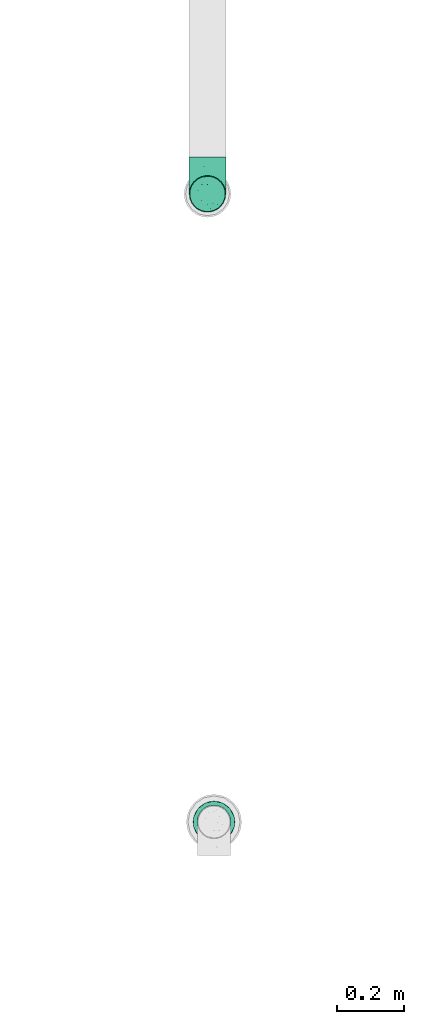
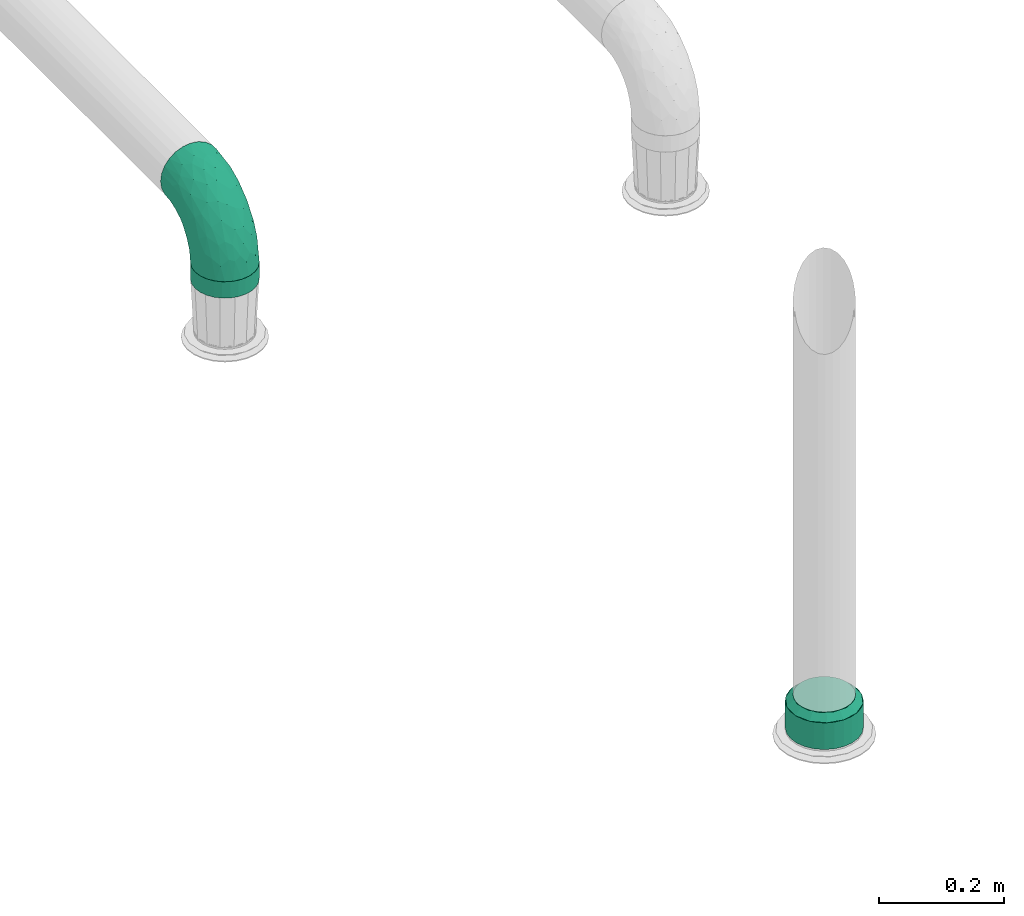
# One storey, part 29 of 103: 2 flow fittings, 1 flow segment.
"""IFC2X3 building model written with IfcOpenShell, lengths in millimetres."""

import ifcopenshell
import ifcopenshell.guid

model = None  # the IFC model being written
_history = None  # IfcOwnerHistory: only IFC2X3 demands one
_inside = {}  # id of a spatial element -> (the spatial element, [elements in it])
_under = {}  # id of a project, library or spatial element -> (it, [spatial elements below it])
_declared = {}  # id of a project -> (the project, [libraries it declares])
_typed = {}  # id of a type object -> (the type object, [elements of that type])
_made_of = {}  # id of a material, layer set ... -> (it, [elements and type objects made of it])


def new_model(schema):
    """Start an empty IFC model of exactly this schema.

    Asked for "IFC4X3", IfcOpenShell would pick the latest addendum, in which some entities
    have other attributes; the version numbers below select the first issue.
    IFC2X3 requires an IfcOwnerHistory on every rooted entity: one is made here for all.
    """
    global model, _history
    if schema == "IFC4X3":
        model = ifcopenshell.file(schema_version=(4, 3, 0, 0))
    else:
        model = ifcopenshell.file(schema=schema)
    _inside.clear()
    _under.clear()
    _declared.clear()
    _typed.clear()
    _made_of.clear()
    _history = None
    if model.schema == "IFC2X3":
        org = make("IfcOrganization", Name="unknown")
        user = make(
            "IfcPersonAndOrganization",
            ThePerson=make("IfcPerson", FamilyName="unknown"),
            TheOrganization=org,
        )
        app = make(
            "IfcApplication",
            ApplicationDeveloper=org,
            Version="unknown",
            ApplicationFullName="unknown",
            ApplicationIdentifier="unknown",
        )
        _history = make(
            "IfcOwnerHistory",
            OwningUser=user,
            OwningApplication=app,
            ChangeAction="ADDED",
            CreationDate=0,
        )
    return model


def make(cls, **values):
    """One entity of the class cls with the attributes given. An attribute that is None is left unset."""
    return model.create_entity(
        cls, **{name: value for name, value in values.items() if value is not None}
    )


def entity(cls, *values):
    """Any entity or typed value of the class cls, its attributes in the order of the schema. None: left unset."""
    e = model.create_entity(cls)
    for i, value in enumerate(values):
        if value is not None:
            e[i] = value
    return e


def rooted(cls, **values):
    """An entity with a GlobalId (a new one), such as an element, a storey or a relation."""
    return make(cls, GlobalId=ifcopenshell.guid.new(), OwnerHistory=_history, **values)


def si_unit(unit_type, name, prefix=None):
    """IfcSIUnit, for example si_unit("LENGTHUNIT", "METRE", prefix="MILLI")."""
    return make("IfcSIUnit", UnitType=unit_type, Prefix=prefix, Name=name)


def converted_unit(unit_type, name, factor, base, dimensions=None, offset=None):
    """IfcConversionBasedUnit, such as the inch: factor (a typed value) times the base unit."""
    return make(
        "IfcConversionBasedUnit"
        if offset is None
        else "IfcConversionBasedUnitWithOffset",
        ConversionOffset=offset,
        Dimensions=None
        if dimensions is None
        else entity("IfcDimensionalExponents", *dimensions),
        UnitType=unit_type,
        Name=name,
        ConversionFactor=make(
            "IfcMeasureWithUnit", ValueComponent=factor, UnitComponent=base
        ),
    )


def derived_unit(unit_type, elements):
    """IfcDerivedUnit: a product of units, each with its exponent."""
    return make(
        "IfcDerivedUnit",
        Elements=[
            make("IfcDerivedUnitElement", Unit=unit, Exponent=power)
            for unit, power in elements
        ],
        UnitType=unit_type,
    )


def assignment(units):
    """IfcUnitAssignment: the units of a project."""
    return None if units is None else make("IfcUnitAssignment", Units=units)


def point(xyz):
    """IfcCartesianPoint."""
    return None if xyz is None else make("IfcCartesianPoint", Coordinates=xyz)


def direction(xyz):
    """IfcDirection."""
    return None if xyz is None else make("IfcDirection", DirectionRatios=xyz)


def frame(location, z_axis=None, x_axis=None):
    """IfcAxis2Placement3D, a coordinate frame: its origin and axes. An axis left out is left unset."""
    return make(
        "IfcAxis2Placement3D",
        Location=point(location),
        Axis=direction(z_axis),
        RefDirection=direction(x_axis),
    )


def frame_2d(location, x_axis=None):
    """IfcAxis2Placement2D, a coordinate frame in the plane: its origin and x axis."""
    return make(
        "IfcAxis2Placement2D", Location=point(location), RefDirection=direction(x_axis)
    )


def origin_with_axes():
    """The frame at (0, 0, 0) with the z axis (0, 0, 1) and the x axis (1, 0, 0) written out."""
    return frame((0.0, 0.0, 0.0), z_axis=(0.0, 0.0, 1.0), x_axis=(1.0, 0.0, 0.0))


def origin_2d_with_axis():
    """The frame at (0, 0) in the plane with the x axis (1, 0) written out."""
    return frame_2d((0.0, 0.0), x_axis=(1.0, 0.0))


def place(relative_to, where):
    """IfcLocalPlacement: puts the frame where relative to a parent placement (None: the world)."""
    return make(
        "IfcLocalPlacement", PlacementRelTo=relative_to, RelativePlacement=where
    )


def context(
    kind, dimensions, precision=None, world=None, true_north=None, identifier=None
):
    """IfcGeometricRepresentationContext, for example the 3D "Model" context."""
    return make(
        "IfcGeometricRepresentationContext",
        ContextIdentifier=identifier,
        ContextType=kind,
        CoordinateSpaceDimension=dimensions,
        Precision=precision,
        WorldCoordinateSystem=world,
        TrueNorth=true_north,
    )


def subcontext(parent, identifier, kind, view, scale=None):
    """IfcGeometricRepresentationSubContext, for example "Body" below "Model"."""
    return make(
        "IfcGeometricRepresentationSubContext",
        ContextIdentifier=identifier,
        ContextType=kind,
        ParentContext=parent,
        TargetScale=scale,
        TargetView=view,
    )


def project(units=None, contexts=None):
    """IfcProject with its units and contexts."""
    return rooted(
        "IfcProject",
        Name="project",
        RepresentationContexts=contexts,
        UnitsInContext=assignment(units),
    )


def spatial(cls, under=None, at=None, **own):
    """A site, building, storey or space (cls), placed at a placement, below another one or the project."""
    s = rooted(cls, ObjectPlacement=at, **own)
    if under is not None:
        _under.setdefault(under.id(), (under, []))[1].append(s)
    return s


def profile(cls, at=None, kind="AREA", **sizes):
    """A parametric profile (cls). Its sizes go by their IFC names, for example OverallWidth=200.0."""
    return make(cls, ProfileType=kind, Position=at, **sizes)


def hollow_circle(**sizes):
    """IfcCircleHollowProfileDef."""
    return profile("IfcCircleHollowProfileDef", **sizes)


def extrude(swept, where, along, depth):
    """IfcExtrudedAreaSolid: the profile swept, set in the frame where, extruded along a direction by depth."""
    return make(
        "IfcExtrudedAreaSolid",
        SweptArea=swept,
        Position=where,
        ExtrudedDirection=direction(along),
        Depth=depth,
    )


def faces_of(points, faces, orient=None, outer=None):
    """IfcFace entities. A face is a list of loops; a loop is a list of indices into points, from 0.

    orient and outer hold one flag for each loop. By default every Orientation is true, the
    first loop of a face is its IfcFaceOuterBound and the others are IfcFaceBound.
    """
    made = []
    for i, loops in enumerate(faces):
        bounds = []
        for j, loop in enumerate(loops):
            is_outer = j == 0 if outer is None else outer[i][j]
            bounds.append(
                make(
                    "IfcFaceOuterBound" if is_outer else "IfcFaceBound",
                    Bound=make("IfcPolyLoop", Polygon=[points[k] for k in loop]),
                    Orientation=True if orient is None else orient[i][j],
                )
            )
        made.append(make("IfcFace", Bounds=bounds))
    return made


def open_shell(faces, orient=None, outer=None):
    """The faces of one IfcOpenShell. surface_model builds it on its shared points."""
    return ("IfcOpenShell", faces, orient, outer)


def surface_model(cls, points, shells):
    """IfcFaceBasedSurfaceModel or IfcShellBasedSurfaceModel (cls): surfaces that need not close."""
    shared = [point(p) for p in points]
    made = [make(c, CfsFaces=faces_of(shared, fs, o, b)) for c, fs, o, b in shells]
    if cls == "IfcFaceBasedSurfaceModel":
        return make(cls, FbsmFaces=made)
    return make(cls, SbsmBoundary=made)


def shape(context_of_items, identifier, shape_type, items):
    """IfcShapeRepresentation: the items that make up one representation, for example the "Body"."""
    return make(
        "IfcShapeRepresentation",
        ContextOfItems=context_of_items,
        RepresentationIdentifier=identifier,
        RepresentationType=shape_type,
        Items=items,
    )


def source(mapping_origin, context_of_items, identifier, shape_type, items):
    """IfcRepresentationMap: a shape defined once, which mapped items show again and again."""
    return make(
        "IfcRepresentationMap",
        MappingOrigin=mapping_origin,
        MappedRepresentation=shape(context_of_items, identifier, shape_type, items),
    )


def transform(
    local_origin,
    x_axis=None,
    y_axis=None,
    z_axis=None,
    scale=None,
    scale2=None,
    scale3=None,
    uniform=True,
):
    """IfcCartesianTransformationOperator3D, or its non-uniform kind. x_axis, y_axis, z_axis: its Axis1, 2, 3."""
    if uniform:
        return make(
            "IfcCartesianTransformationOperator3D",
            Axis1=direction(x_axis),
            Axis2=direction(y_axis),
            LocalOrigin=point(local_origin),
            Scale=scale,
            Axis3=direction(z_axis),
        )
    return make(
        "IfcCartesianTransformationOperator3DnonUniform",
        Axis1=direction(x_axis),
        Axis2=direction(y_axis),
        LocalOrigin=point(local_origin),
        Scale=scale,
        Axis3=direction(z_axis),
        Scale2=scale2,
        Scale3=scale3,
    )


def mapped(mapping_source, mapping_target):
    """IfcMappedItem: shows the shape of a source again, moved by a transform."""
    return make(
        "IfcMappedItem", MappingSource=mapping_source, MappingTarget=mapping_target
    )


def material(Name=None, Category=None):
    """IfcMaterial."""
    return make("IfcMaterial", Name=Name, Category=Category)


def layer(
    of_material, thickness, ventilated=None, Name=None, Category=None, Priority=None
):
    """IfcMaterialLayer: one layer of a wall or slab, of a material (None: an air gap)."""
    return make(
        "IfcMaterialLayer",
        Material=of_material,
        LayerThickness=thickness,
        IsVentilated=ventilated,
        Name=Name,
        Category=Category,
        Priority=Priority,
    )


def layer_set(layers, Name=None):
    """IfcMaterialLayerSet."""
    return make("IfcMaterialLayerSet", MaterialLayers=layers, LayerSetName=Name)


def layer_usage(for_layer_set, set_direction, sense, offset, extent=None):
    """IfcMaterialLayerSetUsage: how a layer set lies in its element."""
    return make(
        "IfcMaterialLayerSetUsage",
        ForLayerSet=for_layer_set,
        LayerSetDirection=set_direction,
        DirectionSense=sense,
        OffsetFromReferenceLine=offset,
        ReferenceExtent=extent,
    )


def made_of(thing, what):
    """Note that an element or type object is made of a material, layer set ...; save() writes the relation."""
    if what is not None:
        _made_of.setdefault(what.id(), (what, []))[1].append(thing)
    return thing


def type_object(cls, material=None, **own):
    """A type object (cls), such as IfcWallType, which elements share."""
    return made_of(rooted(cls, **own), material)


def element(
    cls,
    number,
    at=None,
    inside=None,
    cuts=None,
    type_object=None,
    material=None,
    context=None,
    identifier="Body",
    shape_type=None,
    held_by="IfcProductDefinitionShape",
    body=None,
    shapes=None,
    **own,
):
    """One element of the class cls, such as IfcWall. Its Tag is "e" and its number.

    at: its placement. inside: the storey or other place that contains it. cuts: it is an
    opening in that element (IfcRelVoidsElement). A single representation is given by context,
    identifier, shape_type and body (its items); several are given by shapes. held_by: the class
    of the entity that holds the representations. save() writes the other relations.
    """
    e = rooted(cls, Tag="e%d" % number, ObjectPlacement=at, **own)
    if body is not None:
        shapes = [shape(context, identifier, shape_type, body)]
    if shapes is not None:
        e.Representation = make(held_by, Representations=shapes)
    if inside is not None:
        _inside.setdefault(inside.id(), (inside, []))[1].append(e)
    if cuts is not None:
        rooted(
            "IfcRelVoidsElement", RelatingBuildingElement=cuts, RelatedOpeningElement=e
        )
    if type_object is not None:
        _typed.setdefault(type_object.id(), (type_object, []))[1].append(e)
    return made_of(e, material)


def aggregate(whole, parts):
    """IfcRelAggregates: a whole, such as a stair, and the parts it consists of."""
    return rooted("IfcRelAggregates", RelatingObject=whole, RelatedObjects=parts)


def save(model, path):
    """Write the relations noted so far, then the file.

    IfcRelAggregates (storeys below a building ...), IfcRelContainedInSpatialStructure (elements
    in a storey), IfcRelDefinesByType, IfcRelAssociatesMaterial and IfcRelDeclares: one each for
    every whole, place, type object, material and project.
    """
    for whole, parts in _under.values():
        aggregate(whole, parts)
    for where, things in _inside.values():
        rooted(
            "IfcRelContainedInSpatialStructure",
            RelatedElements=things,
            RelatingStructure=where,
        )
    for kind, things in _typed.values():
        rooted("IfcRelDefinesByType", RelatedObjects=things, RelatingType=kind)
    for what, things in _made_of.values():
        rooted("IfcRelAssociatesMaterial", RelatedObjects=things, RelatingMaterial=what)
    for by, libraries in _declared.values():
        rooted("IfcRelDeclares", RelatingContext=by, RelatedDefinitions=libraries)
    model.write(path)


model = new_model("IFC2X3")

# Units and contexts
model_context = context("Model", 3, precision=1e-05, world=origin_with_axes(), true_north=direction((0.0, 1.0)))
body_context = subcontext(model_context, "Body", "Model", "MODEL_VIEW")
ifc_project = project(units=[si_unit("AREAUNIT", "SQUARE_METRE"), si_unit("VOLUMEUNIT", "CUBIC_METRE", prefix="DECI"), si_unit("TIMEUNIT", "SECOND"), si_unit("THERMODYNAMICTEMPERATUREUNIT", "DEGREE_CELSIUS"), si_unit("PRESSUREUNIT", "PASCAL"), si_unit("MASSUNIT", "GRAM", prefix="KILO"), si_unit("LENGTHUNIT", "METRE", prefix="MILLI"), si_unit("POWERUNIT", "WATT"), si_unit("ELECTRICCURRENTUNIT", "AMPERE"), si_unit("ELECTRICVOLTAGEUNIT", "VOLT"), derived_unit("VOLUMETRICFLOWRATEUNIT", [(si_unit("VOLUMEUNIT", "CUBIC_METRE", prefix="DECI"), 1), (si_unit("TIMEUNIT", "SECOND"), -1)]), derived_unit("LINEARVELOCITYUNIT", [(si_unit("LENGTHUNIT", "METRE"), 1), (si_unit("TIMEUNIT", "SECOND"), -1)]), derived_unit("MASSDENSITYUNIT", [(si_unit("MASSUNIT", "GRAM", prefix="KILO"), 1), (si_unit("VOLUMEUNIT", "CUBIC_METRE"), -1)]), converted_unit("PLANEANGLEUNIT", "DEGREE", entity("IfcRatioMeasure", 0.01745), si_unit("PLANEANGLEUNIT", "RADIAN"), dimensions=[0, 0, 0, 0, 0, 0, 0])], contexts=[model_context])

# Site, building, storey
site_placement = place(None, origin_with_axes())
site = spatial("IfcSite", under=ifc_project, at=site_placement, CompositionType="ELEMENT")
building_placement = place(site_placement, origin_with_axes())
building = spatial("IfcBuilding", under=site, at=building_placement, Name="mc-building", CompositionType="ELEMENT")
storey_placement = place(building_placement, frame((0.0, 0.0, 5900.0), z_axis=(0.0, 0.0, 1.0), x_axis=(1.0, 0.0, 0.0)))
storey = spatial("IfcBuildingStorey", under=building, at=storey_placement, Name="3. Korrus", CompositionType="ELEMENT", Elevation=5900.0)

# Flow segment
ifc_material = material(Name="FZ1")
ifc_layer = layer(ifc_material, 0.0)
ifc_layer_set = layer_set([ifc_layer], Name="FZ1")
ifc_layer_usage = layer_usage(ifc_layer_set, "AXIS1", "POSITIVE", 0.0)
duct_segment_type = type_object("IfcDuctSegmentType", PredefinedType="RIGIDSEGMENT")
shared_shape_1 = source(origin_with_axes(), body_context, "Body", "SweptSolid", [
    extrude(hollow_circle(Radius=55.0, WallThickness=2.0, at=origin_2d_with_axis()), frame((0.0, 0.0, 0.0), z_axis=(1.0, 0.0, 0.0), x_axis=(0.0, 1.0, 0.0)), (0.0, 0.0, 1.0), 31.9),
])
flow_segment_placement = place(storey_placement, frame((11439.21808, 8183.57591, 2235.0), z_axis=(0.0, 1.0, 0.0), x_axis=(0.0, 0.0, -1.0)))
element("IfcFlowSegment", 1, at=flow_segment_placement, inside=storey, type_object=duct_segment_type, material=ifc_layer_usage, context=body_context, shape_type="MappedRepresentation", body=[
    mapped(shared_shape_1, transform((0.0, 0.0, 0.0), scale=1.0)),
])

# Flow fittings
duct_fitting_type_1 = type_object("IfcDuctFittingType", Name="BU", PredefinedType="BEND")
shared_shape_2 = source(origin_with_axes(), body_context, "Body", "SurfaceModel", [
    surface_model("IfcShellBasedSurfaceModel", [(-110.0, 0.0, -55.0), (-110.0, -14.23505, -53.12592), (-110.0, 14.23505, -53.12592), (-110.0, 53.12592, 14.23505), (-110.0, 27.5, -47.63139), (-110.0, 38.89087, -38.89087), (-110.0, -55.0, 0.0), (-110.0, -53.12592, 14.23505), (-110.0, -38.89087, -38.89087), (-110.0, -27.5, -47.63139), (-110.0, -53.12592, -14.23505), (-110.0, -47.63139, -27.5), (-110.0, -14.23505, 53.12592), (-110.0, 14.23505, 53.12592), (-110.0, 27.5, 47.63139), (-110.0, -47.63139, 27.5), (-110.0, -38.89087, 38.89087), (-110.0, -27.5, 47.63139), (-110.0, 0.0, 55.0), (-110.0, 55.0, 0.0), (-110.0, 53.12592, -14.23505), (-110.0, 47.63139, -27.5), (-110.0, 47.63139, 27.5), (-110.0, 38.89087, 38.89087), (-14.23505, 110.0, -53.12592), (-55.0, 110.0, 0.0), (0.0, 110.0, -55.0), (-27.5, 110.0, -47.63139), (-38.89087, 110.0, -38.89087), (-47.63139, 110.0, -27.5), (38.89087, 110.0, -38.89087), (53.12592, 110.0, 14.23505), (27.5, 110.0, -47.63139), (14.23505, 110.0, -53.12592), (47.63139, 110.0, -27.5), (53.12592, 110.0, -14.23505), (55.0, 110.0, 0.0), (-53.12592, 110.0, -14.23505), (-53.12592, 110.0, 14.23505), (-47.63139, 110.0, 27.5), (-38.89087, 110.0, 38.89087), (-27.5, 110.0, 47.63139), (0.0, 110.0, 55.0), (-14.23505, 110.0, 53.12592), (38.89087, 110.0, 38.89087), (47.63139, 110.0, 27.5), (27.5, 110.0, 47.63139), (14.23505, 110.0, 53.12592), (-64.21732, 48.68956, 43.63444), (-76.6405, 38.18013, 45.55988), (-60.44912, 32.56953, 51.94617), (-76.00813, 5.38378, 55.0), (-90.15553, 11.94394, 54.09138), (-78.5998, 26.77405, 50.81338), (-70.18771, 18.55163, 54.03432), (-75.55424, 54.2118, 32.41257), (-93.27622, 45.77614, 33.48188), (-96.12334, 22.13664, 50.81337), (-21.00813, 45.34362, 55.0), (-18.36258, 70.48427, 54.04484), (-32.04182, 59.64019, 52.24446), (-63.88653, 74.77858, 17.99134), (-74.66383, 63.08407, 19.92123), (-63.60674, 66.07878, 29.97482), (-99.597, 52.72185, 18.52927), (-93.11138, 56.59448, 10.50359), (-98.21577, 57.34403, 0.0), (-53.42855, 92.60092, 21.04759), (-88.54852, 54.8376, 21.04759), (-11.86161, 90.23965, 54.10313), (-5.38378, 76.00813, 55.0), (-57.34403, 98.21577, 0.0), (-56.64619, 93.12774, 10.22088), (-45.34362, 21.00813, 55.0), (-44.60838, 44.60838, 52.13415), (-92.68484, 35.46673, 43.63443), (-22.25266, 95.40765, 50.81337), (-35.97783, 90.61597, 43.63443), (-43.70931, 69.58671, 44.47149), (-27.23711, 77.39884, 50.81337), (-57.2828, 79.3123, 24.9774), (-58.67786, 84.31125, 16.04456), (-82.93277, 60.36161, 12.91784), (-49.88337, 54.51816, 47.224), (-74.57753, 66.83759, 9.55742), (-45.35812, 94.97281, 33.48188), (-59.18663, 88.95241, 0.0), (-51.517, 78.6292, 33.48188), (-65.14788, 80.03077, 0.0), (-56.45322, 62.06476, 39.63545), (-88.95241, 59.18663, 0.0), (-71.10913, 71.10913, 0.0), (-80.03077, 65.14788, 0.0), (-94.9309, 45.36788, -33.48188), (-93.11358, 56.60141, -10.46614), (-99.64997, 52.79499, -18.30015), (-90.20425, 36.08686, -43.63443), (-79.99933, 46.56772, -37.92748), (-76.00813, 5.38378, -55.0), (-72.75364, 19.68651, -53.60527), (-45.34362, 21.00813, -55.0), (-21.91957, 65.12078, -53.85897), (-5.38378, 76.00813, -55.0), (-21.00813, 45.34362, -55.0), (-35.41876, 92.89265, -43.63443), (-91.10309, 11.02766, -54.21832), (-45.77614, 93.27622, -33.48188), (-90.50474, 23.21022, -50.81337), (-70.92854, 33.31794, -49.51754), (-78.52933, 63.35627, -11.73997), (-24.91508, 84.05606, -50.81337), (-88.78941, 54.74452, -21.04759), (-69.59921, 57.34866, -33.48187), (-73.36422, 62.46673, -22.94182), (-63.49062, 67.59111, -28.46929), (-56.59448, 93.11138, -10.50359), (-54.8376, 88.54852, -21.04759), (-54.10679, 75.85581, -32.31867), (-57.75956, 31.09612, -52.80882), (-52.72185, 99.597, -18.52927), (-12.62913, 89.46304, -53.99097), (-34.46825, 66.46123, -50.04329), (-43.9837, 43.9837, -52.42279), (-65.78527, 72.58348, -17.68796), (-70.34468, 43.65295, -44.21951), (-57.47001, 51.99467, -44.91465), (-60.72547, 82.29174, -12.88567), (-42.34915, 74.24548, -43.63444), (-57.25194, 63.5016, -38.08211), (-80.95344, 53.56991, -29.32027), (-52.32891, 4.55257, -54.0482), (32.52942, 47.13398, -30.48571), (14.88266, 20.92917, -33.7947), (14.95561, 36.05775, -42.26543), (30.24048, 70.09027, -41.7461), (19.3559, 65.35825, -48.00507), (-70.35075, -46.44478, -19.5952), (-47.13398, -32.52942, -30.48571), (-28.49299, -30.5778, -16.4009), (-4.55257, 52.32891, -54.0482), (-22.4954, 22.4954, -53.25347), (-75.47368, -11.22546, -52.60718), (-81.32209, -51.5606, -9.98467), (-80.81763, -41.84862, -32.14655), (-70.09027, -30.24048, -41.7461), (-36.05774, -14.95561, -42.26543), (-9.15831, -10.852, -27.8997), (-65.35825, -19.3559, -48.00507), (11.22546, 75.47368, -52.60718), (3.94376, 43.9333, -50.53315), (-13.39742, 13.39743, -48.13058), (-43.9333, -3.94376, -50.53315), (49.37776, 67.29486, 0.0), (41.8609, 47.82256, -9.92641), (50.20582, 74.51695, -9.9731), (18.93131, 11.7156, -17.56239), (-27.5, -32.89419, 0.0), (-1.23348, -12.25375, -12.18106), (41.84862, 80.81763, -32.14655), (35.70604, 41.31408, -20.38235), (46.44478, 70.35075, -19.5952), (32.89419, 27.5, 0.0), (6.67262, -6.67262, 0.0), (-67.29486, -49.37776, 0.0), (-50.36265, -42.95545, -9.51562), (-5.47251, 5.47251, -39.92906), (-70.35075, -46.44478, 19.5952), (-74.51695, -50.20582, 9.9731), (-41.31407, -35.70604, 20.38235), (-47.13398, -32.52942, 30.48571), (-80.81763, -41.84862, 32.14655), (-4.55257, 52.32891, 54.0482), (11.22546, 75.47368, 52.60718), (-43.9333, -3.94376, 50.53315), (-65.35825, -19.3559, 48.00507), (-36.05774, -14.95561, 42.26543), (-70.09027, -30.24048, 41.7461), (-11.7156, -18.93131, 17.56239), (30.5778, 28.49299, 16.4009), (12.25375, 1.23348, 12.18106), (51.5606, 81.32209, 9.98467), (42.95545, 50.36265, 9.51562), (-75.47368, -11.22546, 52.60718), (-52.32891, 4.55257, 54.0482), (3.94376, 43.9333, 50.53315), (-22.4954, 22.4954, 53.25347), (-13.39742, 13.39743, 48.13058), (10.852, 9.15831, 27.8997), (-20.92916, -14.88266, 33.79469), (-47.82256, -41.8609, 9.92641), (32.52942, 47.13398, 30.48571), (46.44478, 70.35075, 19.5952), (41.84862, 80.81763, 32.14655), (30.24048, 70.09027, 41.7461), (19.3559, 65.35825, 48.00507), (14.95561, 36.05775, 42.26543), (-5.47251, 5.47251, 39.92906)], [open_shell([[[0, 1, 2]], [[2, 3, 4]], [[4, 3, 5]], [[2, 6, 7]], [[8, 6, 9]], [[1, 9, 6]], [[10, 6, 11]], [[8, 11, 6]], [[6, 2, 1]], [[12, 13, 14]], [[15, 2, 7]], [[16, 17, 2]], [[2, 17, 12]], [[12, 18, 13]], [[19, 20, 3]], [[5, 3, 21]], [[20, 21, 3]], [[22, 3, 2]], [[23, 22, 2]], [[12, 14, 2]], [[2, 14, 23]], [[15, 16, 2]], [[24, 25, 26]], [[27, 25, 24]], [[25, 28, 29]], [[28, 25, 27]], [[30, 26, 31]], [[26, 30, 32]], [[32, 33, 26]], [[34, 31, 35]], [[31, 34, 30]], [[35, 31, 36]], [[29, 37, 25]], [[38, 39, 26]], [[39, 40, 26]], [[41, 42, 40]], [[42, 26, 40]], [[42, 41, 43]], [[26, 44, 45]], [[31, 26, 45]], [[26, 46, 44]], [[47, 46, 26]], [[42, 47, 26]], [[25, 38, 26]], [[48, 49, 50]], [[18, 51, 52]], [[53, 54, 50]], [[55, 56, 49]], [[56, 22, 23]], [[13, 57, 14]], [[58, 59, 60]], [[61, 62, 63]], [[3, 64, 65]], [[53, 52, 54]], [[3, 65, 66]], [[67, 39, 38]], [[56, 68, 64]], [[65, 64, 68]], [[69, 59, 70]], [[38, 71, 72]], [[73, 58, 74]], [[75, 49, 56]], [[76, 69, 43]], [[53, 57, 52]], [[77, 78, 79]], [[41, 76, 43]], [[43, 69, 42]], [[55, 68, 56]], [[23, 14, 75]], [[76, 77, 79]], [[80, 67, 81]], [[62, 82, 68]], [[60, 78, 83]], [[62, 84, 82]], [[85, 77, 40]], [[81, 67, 72]], [[86, 72, 71]], [[87, 85, 67]], [[61, 81, 88]], [[77, 41, 40]], [[78, 77, 87]], [[23, 75, 56]], [[83, 89, 48]], [[85, 40, 39]], [[62, 68, 55]], [[89, 87, 63]], [[83, 48, 50]], [[57, 75, 14]], [[49, 75, 53]], [[67, 85, 39]], [[87, 77, 85]], [[63, 62, 55]], [[89, 55, 48]], [[80, 63, 87]], [[66, 65, 90]], [[66, 19, 3]], [[84, 91, 92]], [[92, 90, 82]], [[65, 82, 90]], [[61, 84, 62]], [[92, 82, 84]], [[68, 82, 65]], [[3, 22, 64]], [[56, 64, 22]], [[38, 25, 71]], [[81, 72, 86]], [[38, 72, 67]], [[91, 61, 88]], [[80, 81, 61]], [[63, 80, 61]], [[67, 80, 87]], [[77, 76, 41]], [[79, 59, 69]], [[79, 69, 76]], [[42, 69, 70]], [[60, 59, 79]], [[58, 70, 59]], [[78, 60, 79]], [[58, 60, 74]], [[52, 57, 13]], [[75, 57, 53]], [[18, 52, 13]], [[52, 51, 54]], [[51, 73, 54]], [[50, 73, 74]], [[73, 50, 54]], [[50, 74, 83]], [[60, 83, 74]], [[89, 83, 78]], [[87, 89, 78]], [[55, 89, 63]], [[50, 49, 53]], [[55, 49, 48]], [[81, 86, 88]], [[91, 84, 61]], [[5, 21, 93]], [[90, 94, 66]], [[20, 94, 95]], [[96, 93, 97]], [[98, 99, 100]], [[96, 4, 5]], [[101, 102, 103]], [[28, 27, 104]], [[2, 105, 0]], [[104, 106, 28]], [[99, 105, 107]], [[108, 107, 96]], [[90, 109, 94]], [[107, 2, 4]], [[20, 66, 94]], [[27, 24, 110]], [[109, 111, 94]], [[112, 113, 114]], [[37, 115, 71]], [[116, 106, 117]], [[99, 118, 100]], [[116, 115, 119]], [[37, 119, 115]], [[24, 120, 110]], [[121, 110, 101]], [[119, 106, 116]], [[101, 110, 120]], [[122, 103, 100]], [[117, 123, 116]], [[124, 125, 108]], [[115, 116, 126]], [[106, 29, 28]], [[26, 102, 120]], [[127, 104, 110]], [[97, 124, 96]], [[125, 122, 118]], [[128, 127, 125]], [[96, 5, 93]], [[115, 126, 86]], [[117, 106, 127]], [[111, 113, 129]], [[95, 93, 21]], [[97, 129, 112]], [[110, 104, 27]], [[106, 104, 127]], [[96, 107, 4]], [[99, 107, 108]], [[99, 108, 118]], [[105, 99, 98]], [[112, 114, 128]], [[121, 125, 127]], [[20, 19, 66]], [[109, 90, 92]], [[94, 111, 95]], [[91, 123, 109]], [[129, 113, 112]], [[93, 95, 111]], [[21, 20, 95]], [[71, 115, 86]], [[71, 25, 37]], [[123, 91, 88]], [[126, 116, 123]], [[123, 88, 126]], [[86, 126, 88]], [[37, 29, 119]], [[106, 119, 29]], [[129, 93, 111]], [[124, 112, 125]], [[0, 105, 98]], [[107, 105, 2]], [[125, 118, 108]], [[100, 118, 122]], [[93, 129, 97]], [[113, 111, 109]], [[109, 123, 113]], [[114, 123, 117]], [[123, 114, 113]], [[128, 114, 117]], [[127, 128, 117]], [[112, 128, 125]], [[103, 122, 101]], [[110, 121, 127]], [[101, 122, 121]], [[125, 121, 122]], [[26, 120, 24]], [[101, 120, 102]], [[96, 124, 108]], [[92, 91, 109]], [[112, 124, 97]], [[100, 130, 98]], [[131, 132, 133]], [[32, 134, 135]], [[136, 137, 138]], [[139, 140, 103]], [[98, 141, 0]], [[142, 10, 136]], [[143, 144, 137]], [[6, 10, 142]], [[137, 145, 146]], [[144, 147, 145]], [[143, 136, 11]], [[11, 136, 10]], [[8, 143, 11]], [[148, 149, 139]], [[8, 9, 144]], [[9, 1, 147]], [[130, 141, 98]], [[103, 140, 100]], [[148, 135, 149]], [[150, 151, 140]], [[152, 153, 154]], [[130, 140, 151]], [[148, 26, 33]], [[147, 1, 141]], [[155, 146, 132]], [[156, 138, 157]], [[134, 30, 158]], [[150, 140, 149]], [[158, 30, 34]], [[30, 134, 32]], [[153, 159, 160]], [[131, 160, 159]], [[144, 145, 137]], [[36, 152, 154]], [[146, 138, 137]], [[155, 161, 162]], [[158, 160, 131]], [[133, 149, 135]], [[156, 163, 164]], [[163, 142, 164]], [[139, 103, 102]], [[153, 152, 161]], [[34, 35, 160]], [[162, 157, 155]], [[132, 165, 133]], [[157, 146, 155]], [[140, 130, 100]], [[141, 130, 151]], [[141, 151, 147]], [[141, 1, 0]], [[102, 26, 148]], [[140, 139, 149]], [[102, 148, 139]], [[135, 33, 32]], [[151, 150, 145]], [[9, 147, 144]], [[151, 145, 147]], [[145, 165, 146]], [[135, 148, 33]], [[133, 135, 134]], [[131, 133, 134]], [[133, 165, 150]], [[133, 150, 149]], [[145, 150, 165]], [[132, 131, 159]], [[146, 165, 132]], [[160, 158, 34]], [[134, 158, 131]], [[144, 143, 8]], [[136, 143, 137]], [[155, 153, 161]], [[154, 153, 160]], [[153, 155, 159]], [[132, 159, 155]], [[160, 35, 154]], [[36, 154, 35]], [[164, 136, 138]], [[6, 142, 163]], [[136, 164, 142]], [[156, 164, 138]], [[156, 157, 162]], [[146, 157, 138]], [[15, 7, 166]], [[6, 163, 167]], [[168, 169, 166]], [[166, 169, 170]], [[171, 172, 70]], [[173, 174, 175]], [[17, 176, 174]], [[177, 156, 162]], [[176, 16, 170]], [[170, 16, 15]], [[161, 178, 179]], [[152, 180, 181]], [[182, 173, 183]], [[18, 12, 182]], [[184, 185, 186]], [[183, 185, 73]], [[183, 73, 51]], [[177, 187, 188]], [[189, 168, 166]], [[187, 178, 190]], [[16, 176, 17]], [[161, 152, 181]], [[45, 191, 31]], [[45, 44, 192]], [[192, 191, 45]], [[180, 36, 31]], [[193, 194, 195]], [[46, 47, 194]], [[193, 195, 190]], [[193, 44, 46]], [[172, 42, 70]], [[185, 58, 73]], [[189, 163, 156]], [[163, 189, 167]], [[70, 58, 171]], [[184, 171, 185]], [[169, 188, 175]], [[180, 31, 191]], [[192, 193, 190]], [[191, 190, 178]], [[182, 174, 173]], [[194, 47, 172]], [[190, 195, 187]], [[186, 185, 173]], [[162, 179, 177]], [[188, 196, 175]], [[179, 187, 177]], [[185, 171, 58]], [[172, 171, 184]], [[172, 184, 194]], [[172, 47, 42]], [[51, 18, 182]], [[185, 183, 173]], [[51, 182, 183]], [[174, 12, 17]], [[184, 186, 195]], [[46, 194, 193]], [[184, 195, 194]], [[195, 196, 187]], [[174, 182, 12]], [[175, 174, 176]], [[169, 175, 176]], [[175, 196, 186]], [[175, 186, 173]], [[195, 186, 196]], [[188, 169, 168]], [[187, 196, 188]], [[166, 170, 15]], [[176, 170, 169]], [[193, 192, 44]], [[191, 192, 190]], [[177, 189, 156]], [[167, 189, 166]], [[189, 177, 168]], [[188, 168, 177]], [[166, 7, 167]], [[6, 167, 7]], [[181, 191, 178]], [[36, 180, 152]], [[191, 181, 180]], [[161, 181, 178]], [[161, 179, 162]], [[187, 179, 178]]])]),
])
flow_fitting_1_placement = place(storey_placement, frame((11439.21808, 8183.57591, 2345.0), z_axis=(1.0, 0.0, 0.0), x_axis=(0.0, -1.0, 0.0)))
element("IfcFlowFitting", 2, at=flow_fitting_1_placement, inside=storey, type_object=duct_fitting_type_1, Name="BU", context=body_context, shape_type="MappedRepresentation", body=[
    mapped(shared_shape_2, transform((0.0, 0.0, 0.0), scale=1.0)),
])
duct_fitting_type_2 = type_object("IfcDuctFittingType", PredefinedType="TRANSITION")
shared_shape_3 = source(origin_with_axes(), body_context, "Body", "SurfaceModel", [
    surface_model("IfcShellBasedSurfaceModel", [(64.0, 45.04844, 21.69419), (64.0, 31.17449, 39.09157), (64.0, 45.04844, -21.69419), (64.0, 11.12605, 48.7464), (64.0, -11.12605, 48.7464), (64.0, -50.0, 0.0), (52.0, -38.96811, 48.86447), (52.0, -13.90756, 60.93299), (52.0, -56.31055, -27.11773), (52.0, 62.5, 0.0), (52.0, 13.90756, 60.93299), (52.0, 38.96811, 48.86447), (52.0, -44.19417, -44.19417), (52.0, -62.5, 0.0), (52.0, -60.37037, -16.17619), (52.0, 60.37037, -16.17619), (52.0, 54.12659, -31.25), (0.0, 60.37037, -16.17619), (0.0, 62.5, 0.0), (0.0, 54.12659, -31.25), (52.0, 44.19417, -44.19417), (52.0, -54.12659, -31.25), (0.0, -54.12659, -31.25), (0.0, -60.37037, -16.17619), (0.0, -62.5, 0.0), (52.0, -60.37037, 16.17619), (52.0, -54.12659, 31.25), (0.0, -60.37037, 16.17619), (0.0, -54.12659, 31.25), (52.0, -44.19417, 44.19417), (52.0, 44.19417, 44.19417), (52.0, 54.12659, 31.25), (0.0, 54.12659, 31.25), (0.0, 60.37037, 16.17619), (52.0, 60.37037, 16.17619), (64.0, -31.17449, 39.09157), (64.0, 50.0, 0.0), (64.0, -45.04844, 21.69419), (64.0, -45.04844, -21.69419), (64.0, -31.17449, -39.09157), (64.0, 31.17449, -39.09157), (64.0, -11.12605, -48.7464), (64.0, 11.12605, -48.7464), (52.0, -56.31055, 27.11773), (52.0, 56.31055, 27.11773), (52.0, -13.90756, -60.93299), (52.0, 56.31055, -27.11773), (52.0, 13.90756, -60.93299), (52.0, 38.96811, -48.86447), (52.0, -38.96811, -48.86447), (64.0, 46.78969, -14.06526), (52.0, 59.40528, -13.55887), (52.0, 26.43783, -54.89873), (64.0, 21.15027, -43.91899), (52.0, 47.63933, -37.9911), (64.0, 38.11147, -30.39288), (64.0, 0.0, -48.7464), (52.0, 0.0, -60.93299), (64.0, -21.15027, -43.91899), (52.0, -26.43783, -54.89873), (64.0, -47.52422, -10.84709), (52.0, -47.63933, -37.9911), (64.0, -38.11147, -30.39288), (52.0, -58.48712, -17.58158), (64.0, -46.78969, 14.06526), (52.0, -59.40528, 13.55887), (52.0, -26.43783, 54.89873), (64.0, -21.15027, 43.91899), (52.0, -47.63933, 37.9911), (64.0, -38.11147, 30.39288), (64.0, 0.0, 48.7464), (52.0, 0.0, 60.93299), (64.0, 21.15027, 43.91899), (52.0, 26.43783, 54.89873), (64.0, 47.52422, 10.84709), (52.0, 47.63933, 37.9911), (64.0, 38.11147, 30.39288), (52.0, 58.48712, 17.58158), (64.0, 12.94095, -48.29629), (64.0, 25.0, -43.30127), (64.0, 35.35534, -35.35534), (64.0, 43.30127, -25.0), (64.0, 48.29629, -12.94095), (64.0, 0.0, -50.0), (64.0, -25.0, -43.30127), (64.0, -12.94095, -48.29629), (64.0, -35.35534, -35.35534), (64.0, -48.29629, -12.94095), (64.0, -43.30127, -25.0), (64.0, -48.29629, 12.94095), (64.0, 48.29629, 12.94095), (64.0, 43.30127, 25.0), (64.0, 35.35534, 35.35534), (64.0, -35.35534, 35.35534), (64.0, 12.94095, 48.29629), (64.0, 25.0, 43.30127), (64.0, 0.0, 50.0), (64.0, -43.30127, 25.0), (64.0, -12.94095, 48.29629), (64.0, -25.0, 43.30127), (62.0, 48.29629, 12.94095), (62.0, 0.0, 50.0), (62.0, 12.94095, 48.29629), (62.0, 25.0, 43.30127), (62.0, 35.35534, 35.35534), (62.0, 43.30127, 25.0), (62.0, -35.35534, 35.35534), (62.0, -12.94095, 48.29629), (62.0, -25.0, 43.30127), (62.0, -48.29629, 12.94095), (62.0, -43.30127, 25.0), (62.0, -25.0, -43.30127), (62.0, -48.29629, -12.94095), (62.0, -50.0, 0.0), (62.0, 48.29629, -12.94095), (62.0, 12.94095, -48.29629), (62.0, 43.30127, -25.0), (62.0, 35.35534, -35.35534), (62.0, 25.0, -43.30127), (62.0, -35.35534, -35.35534), (62.0, -43.30127, -25.0), (62.0, -12.94095, -48.29629), (62.0, 0.0, -50.0), (62.0, 50.0, 0.0), (0.0, 16.17619, 60.37037), (0.0, -44.19417, 44.19417), (0.0, 0.0, 62.5), (0.0, 44.19417, 44.19417), (0.0, 31.25, 54.12659), (0.0, -44.19417, -44.19417), (0.0, -16.17619, 60.37037), (0.0, -31.25, 54.12659), (0.0, 16.17619, -60.37037), (0.0, 44.19417, -44.19417), (0.0, 31.25, -54.12659), (0.0, -31.25, -54.12659), (0.0, 0.0, -62.5), (0.0, -16.17619, -60.37037), (52.0, 16.17619, -60.37037), (52.0, 31.25, -54.12659), (52.0, 0.0, -62.5), (52.0, -31.25, -54.12659), (52.0, -16.17619, -60.37037), (52.0, 16.17619, 60.37037), (52.0, 0.0, 62.5), (52.0, 31.25, 54.12659), (52.0, -16.17619, 60.37037), (52.0, -31.25, 54.12659)], [open_shell([[[0, 1, 2]], [[1, 3, 2]], [[4, 5, 3]], [[6, 7, 8]], [[9, 10, 11]], [[10, 9, 7]], [[12, 13, 14]], [[15, 16, 17]], [[18, 9, 15]], [[19, 16, 20]], [[12, 21, 22]], [[23, 21, 14]], [[14, 13, 24]], [[25, 26, 27]], [[24, 13, 25]], [[28, 26, 29]], [[30, 31, 32]], [[33, 31, 34]], [[34, 9, 18]], [[4, 35, 5]], [[2, 36, 0]], [[35, 37, 5]], [[5, 38, 39]], [[5, 39, 2]], [[40, 2, 41]], [[41, 42, 40]], [[2, 39, 41]], [[5, 2, 3]], [[43, 6, 8]], [[43, 8, 13]], [[44, 9, 11]], [[45, 9, 46]], [[47, 46, 48]], [[8, 9, 49]], [[45, 49, 9]], [[47, 45, 46]], [[9, 8, 7]], [[46, 50, 2]], [[36, 50, 51]], [[52, 53, 42]], [[50, 46, 51]], [[42, 47, 52]], [[54, 55, 40]], [[47, 56, 57]], [[9, 36, 51]], [[45, 58, 59]], [[55, 46, 2]], [[53, 48, 40]], [[39, 49, 59]], [[57, 56, 41]], [[41, 45, 57]], [[59, 58, 39]], [[48, 53, 52]], [[60, 5, 13]], [[40, 48, 54]], [[46, 55, 54]], [[61, 62, 38]], [[63, 38, 60]], [[45, 41, 58]], [[49, 62, 61]], [[49, 39, 62]], [[8, 38, 63]], [[38, 8, 61]], [[42, 56, 47]], [[13, 63, 60]], [[43, 64, 37]], [[5, 64, 65]], [[66, 67, 4]], [[64, 43, 65]], [[4, 7, 66]], [[68, 69, 35]], [[7, 70, 71]], [[13, 5, 65]], [[10, 72, 73]], [[69, 43, 37]], [[67, 6, 35]], [[1, 11, 73]], [[71, 70, 3]], [[3, 10, 71]], [[73, 72, 1]], [[6, 67, 66]], [[74, 36, 9]], [[35, 6, 68]], [[43, 69, 68]], [[75, 76, 0]], [[77, 0, 74]], [[10, 3, 72]], [[11, 76, 75]], [[11, 1, 76]], [[44, 0, 77]], [[0, 44, 75]], [[4, 70, 7]], [[9, 77, 74]], [[78, 79, 80]], [[78, 80, 81]], [[78, 82, 83]], [[82, 78, 81]], [[83, 82, 36]], [[83, 84, 85]], [[83, 36, 84]], [[86, 87, 88]], [[87, 86, 84]], [[84, 89, 87]], [[84, 36, 90]], [[90, 91, 92]], [[93, 90, 92]], [[93, 92, 94]], [[94, 92, 95]], [[93, 94, 96]], [[89, 93, 97]], [[5, 87, 89]], [[93, 98, 99]], [[84, 93, 89]], [[96, 98, 93]], [[84, 90, 93]], [[100, 101, 102]], [[100, 102, 103]], [[104, 105, 100]], [[104, 100, 103]], [[101, 100, 106]], [[107, 106, 108]], [[107, 101, 106]], [[106, 109, 110]], [[109, 106, 111]], [[112, 113, 109]], [[111, 106, 100]], [[100, 114, 111]], [[115, 114, 116]], [[117, 118, 115]], [[117, 115, 116]], [[111, 114, 115]], [[112, 119, 120]], [[119, 112, 111]], [[115, 121, 111]], [[112, 109, 111]], [[122, 121, 115]], [[114, 100, 123]], [[112, 87, 113]], [[120, 88, 112]], [[84, 119, 111]], [[120, 119, 86]], [[85, 111, 121]], [[112, 88, 87]], [[87, 5, 113]], [[85, 84, 111]], [[86, 119, 84]], [[86, 88, 120]], [[83, 85, 121]], [[121, 122, 83]], [[115, 78, 122]], [[118, 79, 115]], [[81, 117, 116]], [[118, 117, 80]], [[82, 116, 114]], [[118, 80, 79]], [[79, 78, 115]], [[36, 82, 114]], [[81, 116, 82]], [[81, 80, 117]], [[123, 36, 114]], [[122, 78, 83]], [[100, 90, 123]], [[105, 91, 100]], [[95, 104, 103]], [[105, 104, 92]], [[94, 103, 102]], [[100, 91, 90]], [[90, 36, 123]], [[94, 95, 103]], [[92, 104, 95]], [[92, 91, 105]], [[96, 94, 102]], [[102, 101, 96]], [[107, 98, 101]], [[108, 99, 107]], [[97, 106, 110]], [[108, 106, 93]], [[89, 110, 109]], [[108, 93, 99]], [[99, 98, 107]], [[5, 89, 109]], [[97, 110, 89]], [[97, 93, 106]], [[113, 5, 109]], [[101, 98, 96]], [[124, 125, 126]], [[127, 124, 128]], [[32, 33, 124]], [[32, 124, 127]], [[124, 129, 125]], [[130, 125, 131]], [[130, 126, 125]], [[125, 27, 28]], [[27, 125, 24]], [[125, 129, 24]], [[124, 33, 18]], [[17, 129, 18]], [[132, 17, 19]], [[133, 134, 132]], [[133, 132, 19]], [[129, 17, 132]], [[23, 129, 22]], [[24, 129, 23]], [[135, 136, 137]], [[136, 135, 129]], [[132, 136, 129]], [[129, 124, 18]], [[138, 139, 20]], [[138, 20, 15]], [[15, 9, 138]], [[15, 20, 16]], [[12, 138, 34]], [[140, 141, 142]], [[141, 140, 12]], [[12, 14, 21]], [[12, 140, 138]], [[34, 138, 9]], [[31, 143, 12]], [[143, 31, 30]], [[144, 12, 143]], [[143, 30, 145]], [[144, 29, 12]], [[25, 29, 26]], [[29, 25, 13]], [[29, 146, 147]], [[13, 12, 29]], [[144, 146, 29]], [[34, 31, 12]], [[23, 14, 24]], [[22, 21, 23]], [[22, 129, 12]], [[129, 135, 141]], [[137, 142, 141]], [[142, 137, 136]], [[12, 129, 141]], [[135, 137, 141]], [[136, 140, 142]], [[138, 132, 134]], [[133, 139, 134]], [[16, 19, 17]], [[133, 19, 20]], [[15, 17, 18]], [[132, 138, 140]], [[134, 139, 138]], [[133, 20, 139]], [[132, 140, 136]], [[33, 34, 18]], [[32, 31, 33]], [[124, 126, 143]], [[127, 30, 32]], [[128, 145, 30]], [[128, 124, 145]], [[124, 143, 145]], [[30, 127, 128]], [[126, 144, 143]], [[146, 130, 131]], [[125, 147, 131]], [[26, 28, 27]], [[125, 28, 29]], [[25, 27, 24]], [[130, 146, 144]], [[131, 147, 146]], [[125, 29, 147]], [[130, 144, 126]]])]),
])
flow_fitting_2_placement = place(storey_placement, frame((11458.64544, 6304.03427, 2461.97044), z_axis=(1.0, 0.0, 0.0), x_axis=(0.0, 0.0, 1.0)))
element("IfcFlowFitting", 3, at=flow_fitting_2_placement, inside=storey, type_object=duct_fitting_type_2, context=body_context, shape_type="MappedRepresentation", body=[
    mapped(shared_shape_3, transform((0.0, 0.0, 0.0), scale=1.0)),
])

save(model, "model.ifc")
